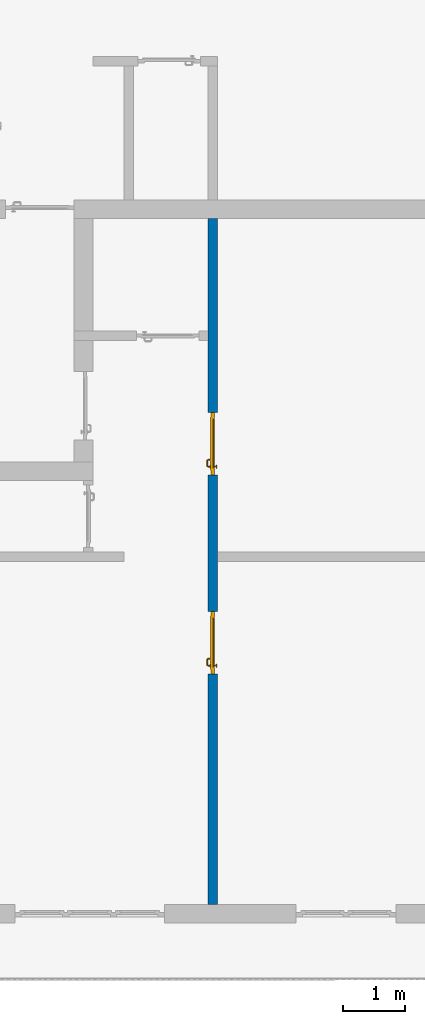
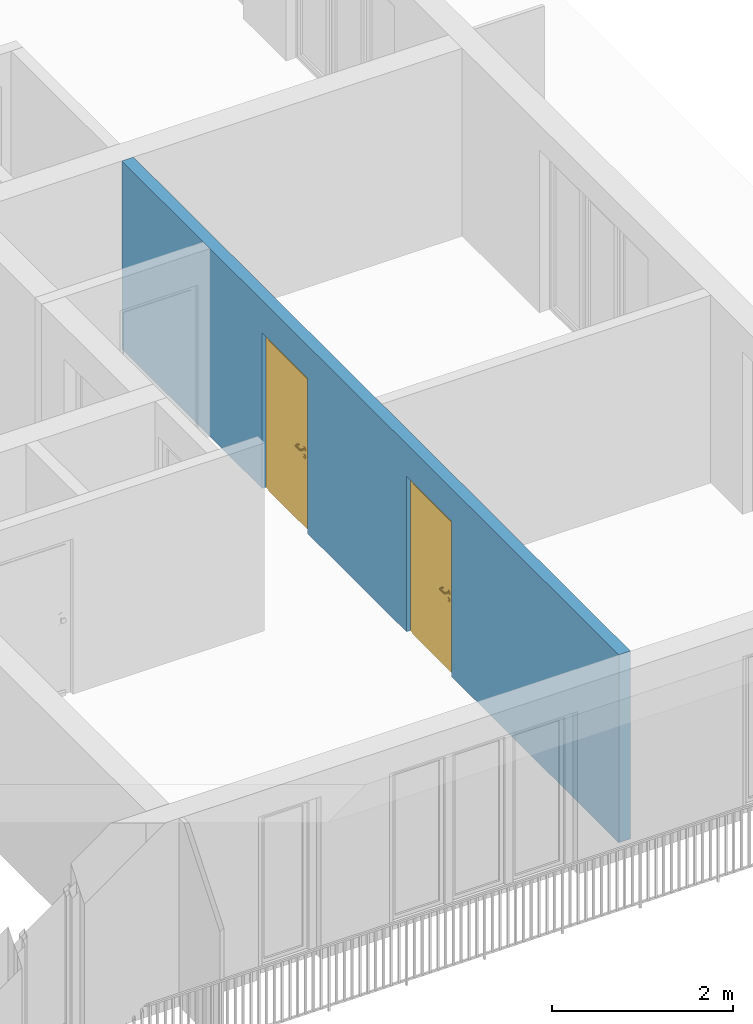
# One storey, part 20 of 54: 2 doors, 1 wall, 2 openings.
"""IFC4 building model written with IfcOpenShell, lengths in metres."""

from ifc_helpers import new_model, entity, si_unit, converted_unit, derived_unit, direction, frame, origin_with_axes, place, context, subcontext, project, spatial, polygons, source, transform, mapped, material, type_object, element, fill, save


model = new_model("IFC4")

# Units and contexts
model_context = context("Model", 3, precision=1e-05, world=origin_with_axes(), true_north=direction((0.0, 1.0)))
body_context = subcontext(model_context, "Body", "Model", "MODEL_VIEW")
ifc_project = project(units=[si_unit("LENGTHUNIT", "METRE"), si_unit("AREAUNIT", "SQUARE_METRE"), si_unit("VOLUMEUNIT", "CUBIC_METRE"), converted_unit("PLANEANGLEUNIT", "DEGREE", entity("IfcPlaneAngleMeasure", 0.0174532925199), si_unit("PLANEANGLEUNIT", "RADIAN"), dimensions=[0, 0, 0, 0, 0, 0, 0]), converted_unit("TIMEUNIT", "Year", entity("IfcTimeMeasure", 31556926.0), si_unit("TIMEUNIT", "SECOND"), dimensions=[0, 0, 1, 0, 0, 0, 0]), si_unit("MASSUNIT", "GRAM", prefix="KILO"), si_unit("THERMODYNAMICTEMPERATUREUNIT", "DEGREE_CELSIUS"), si_unit("LUMINOUSINTENSITYUNIT", "LUMEN"), si_unit("ENERGYUNIT", "JOULE", prefix="MEGA"), derived_unit("THERMALCONDUCTANCEUNIT", [(si_unit("POWERUNIT", "WATT"), 1), (si_unit("LENGTHUNIT", "METRE"), -1), (si_unit("THERMODYNAMICTEMPERATUREUNIT", "KELVIN"), -1)]), derived_unit("SPECIFICHEATCAPACITYUNIT", [(si_unit("ENERGYUNIT", "JOULE"), 1), (si_unit("MASSUNIT", "GRAM", prefix="KILO"), -1), (si_unit("THERMODYNAMICTEMPERATUREUNIT", "KELVIN"), -1)]), derived_unit("MASSDENSITYUNIT", [(si_unit("MASSUNIT", "GRAM", prefix="KILO"), 1), (si_unit("VOLUMEUNIT", "CUBIC_METRE"), -1)])], contexts=[model_context])

# Site, building, storey
site_placement = place(None, origin_with_axes())
site = spatial("IfcSite", under=ifc_project, at=site_placement, CompositionType="ELEMENT")
building_placement = place(site_placement, origin_with_axes())
building = spatial("IfcBuilding", under=site, at=building_placement, CompositionType="ELEMENT")
storey_placement = place(building_placement, frame((0.0, 0.0, 9.18), z_axis=(0.0, 0.0, 1.0), x_axis=(1.0, 0.0, 0.0)))
storey = spatial("IfcBuildingStorey", under=building, at=storey_placement, Name="3. Geschoss", CompositionType="ELEMENT", Elevation=9.18)

# Wall, openings, doors
ifc_material = material()
wall_type = type_object("IfcWallType", Name="150", PredefinedType="NOTDEFINED")
wall_placement = place(storey_placement, frame((4.6878006196, -9.92881223104, 0.0), z_axis=(0.0, 0.0, 1.0), x_axis=(0.0, 1.0, 0.0)))
wall = element("IfcWall", 1, at=wall_placement, inside=storey, type_object=wall_type, material=ifc_material, Name="Wand-002", PredefinedType="NOTDEFINED", context=body_context, shape_type="Tessellation", body=[
    polygons([(4.0, -0.15, 2.1), (4.0, 0.0, 2.1), (5.0, 0.0, 2.1), (5.0, -0.15, 2.1), (4.0, -0.1, 0.0), (4.0, 0.0, 0.0), (4.0, -0.15, 0.0), (0.3, 0.0, 0.0), (0.3, 0.0, 2.54), (11.3, 0.0, 2.54), (11.3, 0.0, 0.0), (8.1921181063, 0.0, 0.0), (8.1921181063, 0.0, 2.1), (7.1921181063, 0.0, 2.1), (7.1921181063, 0.0, 0.0), (5.0, 0.0, 0.0), (5.0, -0.1, 0.0), (5.0, -0.15, 0.0), (11.3, -0.15, 2.54), (0.3, -0.15, 2.54), (0.3, -0.15, 0.0), (7.1921181063, -0.15, 0.0), (7.1921181063, -0.15, 2.1), (8.1921181063, -0.15, 2.1), (8.1921181063, -0.15, 0.0), (11.3, -0.15, 0.0)], [[[1, 2, 3, 4]], [[5, 6, 2, 1, 7]], [[2, 6, 8, 9, 10, 11, 12, 13, 14, 15, 16, 3]], [[4, 3, 16, 17, 18]], [[19, 20, 21, 7, 1, 4, 18, 22, 23, 24, 25, 26]], [[6, 5, 7, 21, 8]], [[21, 20, 9, 8]], [[9, 20, 19, 10]], [[11, 10, 19, 26]], [[26, 25, 12, 11]], [[25, 24, 13, 12]], [[13, 24, 23, 14]], [[23, 22, 15, 14]], [[17, 16, 15, 22, 18]]], closed=True),
])
opening_1_placement = place(wall_placement, frame((7.6921181063, 0.0, 0.0), z_axis=(0.0, 0.0, 1.0), x_axis=(1.0, 0.0, 0.0)))
opening_1 = element("IfcOpeningElement", 2, at=opening_1_placement, cuts=wall, context=body_context, identifier="Reference", shape_type="Tessellation", body=[
    polygons([(0.5, -0.1, 0.0), (0.5, -0.1, 2.1), (0.5, -0.151, 2.1), (0.5, -0.151, 0.0), (0.5, 0.001, 0.0), (0.5, 0.001, 2.1), (-0.5, -0.1, 2.1), (-0.5, -0.151, 2.1), (-0.5, 0.001, 2.1), (-0.5, -0.151, 0.0), (-0.5, -0.1, 0.0), (-0.5, 0.001, 0.0)], [[[1, 2, 3, 4]], [[2, 1, 5, 6]], [[7, 8, 3, 2, 6, 9]], [[8, 10, 4, 3]], [[1, 4, 10, 11, 12, 5]], [[6, 5, 12, 9]], [[7, 11, 10, 8]], [[11, 7, 9, 12]]], closed=True),
])
opening_2_placement = place(wall_placement, frame((4.5, 0.0, 0.0), z_axis=(0.0, 0.0, 1.0), x_axis=(1.0, 0.0, 0.0)))
opening_2 = element("IfcOpeningElement", 3, at=opening_2_placement, cuts=wall, context=body_context, identifier="Reference", shape_type="Tessellation", body=[
    polygons([(0.5, -0.1, 0.0), (0.5, -0.1, 2.1), (0.5, -0.151, 2.1), (0.5, -0.151, 0.0), (0.5, 0.001, 0.0), (0.5, 0.001, 2.1), (-0.5, -0.1, 2.1), (-0.5, -0.151, 2.1), (-0.5, 0.001, 2.1), (-0.5, -0.151, 0.0), (-0.5, -0.1, 0.0), (-0.5, 0.001, 0.0)], [[[1, 2, 3, 4]], [[2, 1, 5, 6]], [[7, 8, 3, 2, 6, 9]], [[8, 10, 4, 3]], [[1, 4, 10, 11, 12, 5]], [[6, 5, 12, 9]], [[7, 11, 10, 8]], [[11, 7, 9, 12]]], closed=True),
])
door_type = type_object("IfcDoorType", Name="Eingang 01 1-Fl 26", OperationType="SINGLE_SWING_RIGHT", PredefinedType="DOOR")
shared_shape = source(origin_with_axes(), body_context, "Body", "Tessellation", [
    polygons([(0.5, -0.05, 0.0), (0.5, -0.03, 0.0), (0.5, -0.03, 2.1), (0.5, -0.05, 2.1), (0.4, -0.05, 0.0), (0.4, -0.03, 0.0), (0.4, -0.03, 2.0), (0.1301, -0.03, 2.0), (0.0001, -0.03, 2.0), (-0.4, -0.03, 2.0), (-0.4, -0.03, 0.0), (-0.5, -0.03, 0.0), (-0.5, -0.03, 2.1), (-0.5, -0.05, 2.1), (-0.5, -0.05, 0.0), (-0.4, -0.05, 0.0), (-0.4, -0.05, 2.0), (0.0001, -0.05, 2.0), (0.1301, -0.05, 2.0), (0.4, -0.05, 2.0)], [[[1, 2, 3, 4]], [[5, 6, 2, 1]], [[2, 6, 7, 8, 9, 10, 11, 12, 13, 3]], [[4, 3, 13, 14]], [[1, 4, 14, 15, 16, 17, 18, 19, 20, 5]], [[20, 7, 6, 5]], [[19, 8, 7, 20]], [[18, 9, 8, 19]], [[17, 10, 9, 18]], [[16, 11, 10, 17]], [[15, 12, 11, 16]], [[14, 13, 12, 15]]], closed=True),
    polygons([(0.5, -0.03, 0.0), (0.5, 0.0, 0.0), (0.5, 0.0, 2.1), (0.5, -0.03, 2.1), (0.43, -0.03, 0.0), (0.43, 0.0, 0.0), (0.43, 0.0, 2.03), (0.1001, 0.0, 2.03), (0.0301, 0.0, 2.03), (-0.43, 0.0, 2.03), (-0.43, 0.0, 0.0), (-0.5, 0.0, 0.0), (-0.5, 0.0, 2.1), (-0.5, -0.03, 2.1), (-0.5, -0.03, 0.0), (-0.43, -0.03, 0.0), (-0.43, -0.03, 2.03), (0.0301, -0.03, 2.03), (0.1001, -0.03, 2.03), (0.43, -0.03, 2.03)], [[[1, 2, 3, 4]], [[5, 6, 2, 1]], [[2, 6, 7, 8, 9, 10, 11, 12, 13, 3]], [[4, 3, 13, 14]], [[1, 4, 14, 15, 16, 17, 18, 19, 20, 5]], [[20, 7, 6, 5]], [[19, 8, 7, 20]], [[18, 9, 8, 19]], [[17, 10, 9, 18]], [[16, 11, 10, 17]], [[15, 12, 11, 16]], [[14, 13, 12, 15]]], closed=True),
    polygons([(0.43, 0.01, 0.0), (-0.43, 0.01, 0.0), (-0.43, 0.01, 2.03), (0.43, 0.01, 2.03), (0.43, -0.03, 0.0), (-0.43, -0.03, 0.0), (-0.43, -0.03, 2.03), (0.43, -0.03, 2.03)], [[[1, 2, 3, 4]], [[2, 1, 5, 6]], [[3, 2, 6, 7]], [[4, 3, 7, 8]], [[1, 4, 8, 5]], [[6, 5, 8, 7]]], closed=True),
    polygons([(0.395, -0.05, 0.0), (0.395, -0.05, 0.05), (-0.395, -0.05, 0.05), (-0.395, -0.05, 0.0), (0.395, -0.03, 0.0), (0.395, -0.03, 0.07), (0.395, -0.035, 0.07), (-0.395, -0.035, 0.07), (-0.395, -0.03, 0.07), (-0.395, -0.03, 0.0)], [[[1, 2, 3, 4]], [[1, 5, 6, 7, 2]], [[2, 7, 8, 3]], [[4, 3, 8, 9, 10]], [[5, 1, 4, 10]], [[6, 5, 10, 9]], [[7, 6, 9, 8]]], closed=True),
    polygons([(-0.3835, 0.02, 1.0733826859), (-0.3835, 0.0199, 1.0733826859), (-0.37, 0.0199, 1.077), (-0.37, 0.02, 1.077), (-0.393382685902, 0.02, 1.0635), (-0.393382685902, 0.0199, 1.0635), (-0.3835, 0.0101, 1.0733826859), (-0.37, 0.0101, 1.077), (-0.3565, 0.0199, 1.0733826859), (-0.3565, 0.02, 1.0733826859), (-0.346617314098, 0.02, 1.0635), (-0.343, 0.02, 1.05), (-0.346617314098, 0.02, 1.0365), (-0.3565, 0.02, 1.0266173141), (-0.37, 0.02, 1.023), (-0.3835, 0.02, 1.0266173141), (-0.393382685902, 0.02, 1.0365), (-0.397, 0.02, 1.05), (-0.397, 0.0199, 1.05), (-0.393382685902, 0.0101, 1.0635), (-0.3835, 0.01, 1.0733826859), (-0.37, 0.01, 1.077), (-0.3565, 0.0101, 1.0733826859), (-0.346617314098, 0.0199, 1.0635), (-0.343, 0.0199, 1.05), (-0.346617314098, 0.0199, 1.0365), (-0.3565, 0.0199, 1.0266173141), (-0.37, 0.0199, 1.023), (-0.3835, 0.0199, 1.0266173141), (-0.393382685902, 0.0199, 1.0365), (-0.397, 0.0101, 1.05), (-0.393382685902, 0.01, 1.0635), (-0.397, 0.01, 1.05), (-0.393382685902, 0.01, 1.0365), (-0.3835, 0.01, 1.0266173141), (-0.37, 0.01, 1.023), (-0.3565, 0.01, 1.0266173141), (-0.346617314098, 0.01, 1.0365), (-0.343, 0.01, 1.05), (-0.346617314098, 0.01, 1.0635), (-0.3565, 0.01, 1.0733826859), (-0.346617314098, 0.0101, 1.0635), (-0.343, 0.0101, 1.05), (-0.346617314098, 0.0101, 1.0365), (-0.3565, 0.0101, 1.0266173141), (-0.37, 0.0101, 1.023), (-0.3835, 0.0101, 1.0266173141), (-0.393382685902, 0.0101, 1.0365)], [[[1, 2, 3, 4]], [[5, 6, 2, 1]], [[2, 7, 8, 3]], [[4, 3, 9, 10]], [[4, 10, 11, 12, 13, 14, 15, 16, 17, 18, 5, 1]], [[18, 19, 6, 5]], [[6, 20, 7, 2]], [[7, 21, 22, 8]], [[3, 8, 23, 9]], [[10, 9, 24, 11]], [[11, 24, 25, 12]], [[12, 25, 26, 13]], [[13, 26, 27, 14]], [[14, 27, 28, 15]], [[15, 28, 29, 16]], [[16, 29, 30, 17]], [[17, 30, 19, 18]], [[19, 31, 20, 6]], [[20, 32, 21, 7]], [[22, 21, 32, 33, 34, 35, 36, 37, 38, 39, 40, 41]], [[8, 22, 41, 23]], [[9, 23, 42, 24]], [[24, 42, 43, 25]], [[25, 43, 44, 26]], [[26, 44, 45, 27]], [[27, 45, 46, 28]], [[28, 46, 47, 29]], [[29, 47, 48, 30]], [[30, 48, 31, 19]], [[31, 33, 32, 20]], [[48, 34, 33, 31]], [[47, 35, 34, 48]], [[46, 36, 35, 47]], [[45, 37, 36, 46]], [[44, 38, 37, 45]], [[43, 39, 38, 44]], [[42, 40, 39, 43]], [[23, 41, 40, 42]]], closed=True),
    polygons([(-0.362532169224, 0.019, 0.959692280177), (-0.365, 0.019, 0.9544), (-0.365, 0.019, 0.952886751346), (-0.347569942042, 0.019, 0.96295), (-0.35705, 0.019, 0.972430057958), (-0.363279754556, 0.019, 0.961639806549), (-0.362532169224, 0.02, 0.959692280177), (-0.365, 0.02, 0.9544), (-0.365, 0.02, 0.952886751346), (-0.365, 0.02, 0.95), (-0.365, 0.02, 0.947113248654), (-0.365, 0.02, 0.941339745962), (-0.365, 0.02, 0.9375), (-0.365, 0.019, 0.9375), (-0.365, 0.019, 0.941339745962), (-0.365, 0.019, 0.947113248654), (-0.365, 0.019, 0.95), (-0.3441, 0.019, 0.95), (-0.347483339502, 0.019, 0.963), (-0.357, 0.019, 0.972516660498), (-0.364624817685, 0.019, 0.965143815798), (-0.37, 0.019, 0.9759), (-0.37, 0.019, 0.967425445323), (-0.364624817685, 0.02, 0.965143815798), (-0.363279754556, 0.02, 0.961639806549), (-0.35655, 0.02, 0.973296083362), (-0.346703916638, 0.02, 0.96345), (-0.3431, 0.02, 0.95), (-0.346703916638, 0.02, 0.93655), (-0.35655, 0.02, 0.926703916638), (-0.37, 0.02, 0.9231), (-0.37, 0.02, 0.9325), (-0.366464466094, 0.02, 0.933964466094), (-0.366464466094, 0.019, 0.933964466094), (-0.35705, 0.019, 0.927569942042), (-0.37, 0.019, 0.9325), (-0.37, 0.019, 0.9241), (-0.347569942042, 0.019, 0.93705), (-0.344, 0.019, 0.95), (-0.347483339502, 0.0189, 0.963), (-0.357, 0.0189, 0.972516660498), (-0.37, 0.019, 0.976), (-0.375375182315, 0.019, 0.965143815798), (-0.38295, 0.019, 0.972430057958), (-0.376720245444, 0.019, 0.961639806549), (-0.37, 0.02, 0.967425445323), (-0.37, 0.02, 0.9769), (-0.346617314098, 0.02, 0.9635), (-0.3565, 0.02, 0.973382685902), (-0.343, 0.02, 0.95), (-0.346617314098, 0.02, 0.9365), (-0.3565, 0.02, 0.926617314098), (-0.38345, 0.02, 0.926703916638), (-0.375, 0.02, 0.941339745962), (-0.375, 0.02, 0.9375), (-0.373535533906, 0.02, 0.933964466094), (-0.37, 0.02, 0.923), (-0.373535533906, 0.019, 0.933964466094), (-0.375, 0.019, 0.9375), (-0.375, 0.019, 0.941339745962), (-0.38295, 0.019, 0.927569942042), (-0.37, 0.019, 0.924), (-0.357, 0.019, 0.927483339502), (-0.347483339502, 0.019, 0.937), (-0.344, 0.0189, 0.95), (-0.347483339502, 0.0101, 0.963), (-0.357, 0.0101, 0.972516660498), (-0.37, 0.0189, 0.976), (-0.383, 0.019, 0.972516660498), (-0.375375182315, 0.02, 0.965143815798), (-0.377467830776, 0.019, 0.959692280177), (-0.392430057958, 0.019, 0.96295), (-0.375, 0.019, 0.952886751346), (-0.375, 0.019, 0.9544), (-0.377467830776, 0.02, 0.959692280177), (-0.376720245444, 0.02, 0.961639806549), (-0.38345, 0.02, 0.973296083362), (-0.37, 0.02, 0.977), (-0.346617314098, 0.0199, 0.9635), (-0.3565, 0.0199, 0.973382685902), (-0.343, 0.0199, 0.95), (-0.346617314098, 0.0199, 0.9365), (-0.3565, 0.0199, 0.926617314098), (-0.393296083362, 0.02, 0.93655), (-0.375, 0.02, 0.947113248654), (-0.375, 0.02, 0.9544), (-0.375, 0.019, 0.95), (-0.375, 0.019, 0.947113248654), (-0.375, 0.02, 0.95), (-0.375, 0.02, 0.952886751346), (-0.3835, 0.02, 0.926617314098), (-0.37, 0.0199, 0.923), (-0.392430057958, 0.019, 0.93705), (-0.383, 0.019, 0.927483339502), (-0.37, 0.0189, 0.924), (-0.357, 0.0189, 0.927483339502), (-0.347483339502, 0.0189, 0.937), (-0.344, 0.0101, 0.95), (-0.347483339502, 0.01, 0.963), (-0.357, 0.01, 0.972516660498), (-0.37, 0.0101, 0.976), (-0.383, 0.0189, 0.972516660498), (-0.392516660498, 0.019, 0.963), (-0.3959, 0.019, 0.95), (-0.393296083362, 0.02, 0.96345), (-0.3835, 0.02, 0.973382685902), (-0.37, 0.0199, 0.977), (-0.346617314098, 0.0101, 0.9635), (-0.3565, 0.0101, 0.973382685902), (-0.343, 0.0101, 0.95), (-0.346617314098, 0.0101, 0.9365), (-0.3565, 0.0101, 0.926617314098), (-0.393382685902, 0.02, 0.9365), (-0.3969, 0.02, 0.95), (-0.3835, 0.0199, 0.926617314098), (-0.37, 0.0101, 0.923), (-0.392516660498, 0.019, 0.937), (-0.383, 0.0189, 0.927483339502), (-0.37, 0.0101, 0.924), (-0.357, 0.0101, 0.927483339502), (-0.347483339502, 0.0101, 0.937), (-0.344, 0.01, 0.95), (-0.347396736961, 0.01, 0.96305), (-0.35695, 0.01, 0.972603263039), (-0.37, 0.01, 0.976), (-0.383, 0.0101, 0.972516660498), (-0.392516660498, 0.0189, 0.963), (-0.396, 0.019, 0.95), (-0.393382685902, 0.02, 0.9635), (-0.3835, 0.0199, 0.973382685902), (-0.37, 0.0101, 0.977), (-0.346617314098, 0.01, 0.9635), (-0.3565, 0.01, 0.973382685902), (-0.343, 0.01, 0.95), (-0.346617314098, 0.01, 0.9365), (-0.3565, 0.01, 0.926617314098), (-0.397, 0.02, 0.95), (-0.393382685902, 0.0199, 0.9365), (-0.3835, 0.0101, 0.926617314098), (-0.37, 0.01, 0.923), (-0.392516660498, 0.0189, 0.937), (-0.383, 0.0101, 0.927483339502), (-0.37, 0.01, 0.924), (-0.357, 0.01, 0.927483339502), (-0.347483339502, 0.01, 0.937), (-0.3439, 0.01, 0.95), (-0.346703916638, 0.01, 0.96345), (-0.35655, 0.01, 0.973296083362), (-0.37, 0.01, 0.9761), (-0.383, 0.01, 0.972516660498), (-0.392516660498, 0.0101, 0.963), (-0.396, 0.0189, 0.95), (-0.393382685902, 0.0199, 0.9635), (-0.3835, 0.0101, 0.973382685902), (-0.37, 0.01, 0.977), (-0.3431, 0.01, 0.95), (-0.346703916638, 0.01, 0.93655), (-0.35655, 0.01, 0.926703916638), (-0.397, 0.0199, 0.95), (-0.393382685902, 0.0101, 0.9365), (-0.3835, 0.01, 0.926617314098), (-0.37, 0.01, 0.9231), (-0.392516660498, 0.0101, 0.937), (-0.383, 0.01, 0.927483339502), (-0.37, 0.01, 0.9239), (-0.35695, 0.01, 0.927396736961), (-0.347396736961, 0.01, 0.93695), (-0.37, 0.01, 0.9769), (-0.38305, 0.01, 0.972603263039), (-0.392516660498, 0.01, 0.963), (-0.396, 0.0101, 0.95), (-0.393382685902, 0.0101, 0.9635), (-0.3835, 0.01, 0.973382685902), (-0.397, 0.0101, 0.95), (-0.393382685902, 0.01, 0.9365), (-0.38345, 0.01, 0.926703916638), (-0.392516660498, 0.01, 0.937), (-0.38305, 0.01, 0.927396736961), (-0.38345, 0.01, 0.973296083362), (-0.392603263039, 0.01, 0.96305), (-0.396, 0.01, 0.95), (-0.393382685902, 0.01, 0.9635), (-0.397, 0.01, 0.95), (-0.393296083362, 0.01, 0.93655), (-0.392603263039, 0.01, 0.93695), (-0.393296083362, 0.01, 0.96345), (-0.3961, 0.01, 0.95), (-0.3969, 0.01, 0.95)], [[[1, 2, 3, 4, 5, 6]], [[2, 1, 7, 8]], [[2, 8, 9, 10, 11, 12, 13, 14, 15, 16, 17, 3]], [[17, 18, 4, 3]], [[4, 19, 20, 5]], [[21, 6, 5, 22, 23]], [[1, 6, 21, 24, 25, 7]], [[7, 25, 26, 27, 9, 8]], [[9, 27, 28, 10]], [[10, 28, 29, 11]], [[11, 29, 30, 12]], [[31, 32, 33, 13, 12, 30]], [[14, 13, 33, 34]], [[35, 15, 14, 34, 36, 37]], [[15, 35, 38, 16]], [[16, 38, 18, 17]], [[18, 39, 19, 4]], [[19, 40, 41, 20]], [[5, 20, 42, 22]], [[43, 23, 22, 44, 45]], [[21, 23, 46, 24]], [[24, 46, 47, 26, 25]], [[48, 27, 26, 49]], [[50, 28, 27, 48]], [[51, 29, 28, 50]], [[52, 30, 29, 51]], [[53, 54, 55, 56, 32, 31]], [[34, 33, 32, 36]], [[57, 31, 30, 52]], [[37, 36, 58, 59, 60, 61]], [[37, 62, 63, 35]], [[35, 63, 64, 38]], [[38, 64, 39, 18]], [[39, 65, 40, 19]], [[40, 66, 67, 41]], [[20, 41, 68, 42]], [[22, 42, 69, 44]], [[23, 43, 70, 46]], [[71, 45, 44, 72, 73, 74]], [[43, 45, 71, 75, 76, 70]], [[70, 76, 77, 47, 46]], [[49, 26, 47, 78]], [[79, 48, 49, 80]], [[81, 50, 48, 79]], [[82, 51, 50, 81]], [[83, 52, 51, 82]], [[54, 53, 84, 85]], [[86, 74, 73, 87, 88, 60, 59, 55, 54, 85, 89, 90]], [[58, 56, 55, 59]], [[36, 32, 56, 58]], [[91, 53, 31, 57]], [[92, 57, 52, 83]], [[88, 93, 61, 60]], [[61, 94, 62, 37]], [[62, 95, 96, 63]], [[63, 96, 97, 64]], [[64, 97, 65, 39]], [[65, 98, 66, 40]], [[66, 99, 100, 67]], [[41, 67, 101, 68]], [[42, 68, 102, 69]], [[44, 69, 103, 72]], [[73, 72, 104, 87]], [[71, 74, 86, 75]], [[75, 86, 90, 105, 77, 76]], [[78, 47, 77, 106]], [[80, 49, 78, 107]], [[108, 79, 80, 109]], [[110, 81, 79, 108]], [[111, 82, 81, 110]], [[112, 83, 82, 111]], [[113, 84, 53, 91]], [[85, 84, 114, 89]], [[87, 104, 93, 88]], [[89, 114, 105, 90]], [[115, 91, 57, 92]], [[116, 92, 83, 112]], [[93, 117, 94, 61]], [[94, 118, 95, 62]], [[95, 119, 120, 96]], [[96, 120, 121, 97]], [[97, 121, 98, 65]], [[98, 122, 99, 66]], [[99, 123, 124, 100]], [[67, 100, 125, 101]], [[68, 101, 126, 102]], [[69, 102, 127, 103]], [[72, 103, 128, 104]], [[106, 77, 105, 129]], [[107, 78, 106, 130]], [[109, 80, 107, 131]], [[132, 108, 109, 133]], [[134, 110, 108, 132]], [[135, 111, 110, 134]], [[136, 112, 111, 135]], [[137, 114, 84, 113]], [[138, 113, 91, 115]], [[104, 128, 117, 93]], [[129, 105, 114, 137]], [[139, 115, 92, 116]], [[140, 116, 112, 136]], [[117, 141, 118, 94]], [[118, 142, 119, 95]], [[119, 143, 144, 120]], [[120, 144, 145, 121]], [[121, 145, 122, 98]], [[122, 146, 123, 99]], [[123, 147, 148, 124]], [[100, 124, 149, 125]], [[101, 125, 150, 126]], [[102, 126, 151, 127]], [[103, 127, 152, 128]], [[130, 106, 129, 153]], [[131, 107, 130, 154]], [[133, 109, 131, 155]], [[147, 132, 133, 148]], [[156, 134, 132, 147]], [[157, 135, 134, 156]], [[158, 136, 135, 157]], [[159, 137, 113, 138]], [[160, 138, 115, 139]], [[128, 152, 141, 117]], [[153, 129, 137, 159]], [[161, 139, 116, 140]], [[162, 140, 136, 158]], [[141, 163, 142, 118]], [[142, 164, 143, 119]], [[143, 165, 166, 144]], [[144, 166, 167, 145]], [[145, 167, 146, 122]], [[146, 156, 147, 123]], [[124, 148, 168, 149]], [[125, 149, 169, 150]], [[126, 150, 170, 151]], [[127, 151, 171, 152]], [[154, 130, 153, 172]], [[155, 131, 154, 173]], [[148, 133, 155, 168]], [[167, 157, 156, 146]], [[166, 158, 157, 167]], [[174, 159, 138, 160]], [[175, 160, 139, 161]], [[152, 171, 163, 141]], [[172, 153, 159, 174]], [[176, 161, 140, 162]], [[165, 162, 158, 166]], [[163, 177, 164, 142]], [[164, 178, 165, 143]], [[149, 168, 179, 169]], [[150, 169, 180, 170]], [[151, 170, 181, 171]], [[173, 154, 172, 182]], [[168, 155, 173, 179]], [[183, 174, 160, 175]], [[184, 175, 161, 176]], [[171, 181, 177, 163]], [[182, 172, 174, 183]], [[178, 176, 162, 165]], [[177, 185, 178, 164]], [[169, 179, 186, 180]], [[170, 180, 187, 181]], [[179, 173, 182, 186]], [[188, 183, 175, 184]], [[185, 184, 176, 178]], [[181, 187, 185, 177]], [[186, 182, 183, 188]], [[180, 186, 188, 187]], [[187, 188, 184, 185]]], closed=True),
    polygons([(-0.38, 0.02, 1.05), (-0.38, 0.0509849140336, 1.05), (-0.377071067812, 0.050696439392, 1.04292893219), (-0.377071067812, 0.02, 1.04292893219), (-0.377071067812, 0.02, 1.05707106781), (-0.377071067812, 0.050696439392, 1.05707106781), (-0.378277987014, 0.0596420579258, 1.05), (-0.375518993221, 0.0584992452783, 1.04292893219), (-0.37, 0.05, 1.04), (-0.37, 0.02, 1.04), (-0.37, 0.02, 1.06), (-0.37, 0.05, 1.06), (-0.375518993221, 0.0584992452783, 1.05707106781), (-0.372816199938, 0.0678161999379, 1.05), (-0.370704557509, 0.0657045575088, 1.04292893219), (-0.368858192988, 0.0557402514855, 1.04), (-0.362928932188, 0.049303560608, 1.04292893219), (-0.362928932188, 0.02, 1.04292893219), (-0.362928932188, 0.02, 1.05707106781), (-0.362928932188, 0.049303560608, 1.05707106781), (-0.368858192988, 0.0557402514855, 1.06), (-0.370704557509, 0.0657045575088, 1.05707106781), (-0.364642057926, 0.0732779870137, 1.05), (-0.363499245278, 0.0705189932208, 1.04292893219), (-0.365606601718, 0.0606066017178, 1.04), (-0.362197392755, 0.0529812576926, 1.04292893219), (-0.36, 0.0490150859664, 1.05), (-0.36, 0.02, 1.05), (-0.362197392755, 0.0529812576926, 1.05707106781), (-0.365606601718, 0.0606066017178, 1.06), (-0.363499245278, 0.0705189932208, 1.05707106781), (-0.355984914034, 0.075, 1.05), (-0.355696439392, 0.0720710678119, 1.04292893219), (-0.360740251485, 0.0638581929877, 1.04), (-0.360508645927, 0.0555086459268, 1.04292893219), (-0.359438398962, 0.0518384450452, 1.05), (-0.360508645927, 0.0555086459268, 1.05707106781), (-0.360740251485, 0.0638581929877, 1.06), (-0.355696439392, 0.0720710678119, 1.05707106781), (-0.274015085966, 0.075, 1.05), (-0.274303560608, 0.0720710678119, 1.04292893219), (-0.355, 0.065, 1.04), (-0.357981257693, 0.0571973927545, 1.04292893219), (-0.358397003498, 0.0533970034977, 1.05), (-0.357981257693, 0.0571973927545, 1.05707106781), (-0.355, 0.065, 1.06), (-0.274303560608, 0.0720710678119, 1.05707106781), (-0.265357942074, 0.0732779870137, 1.05), (-0.266500754722, 0.0705189932208, 1.04292893219), (-0.275, 0.065, 1.04), (-0.354303560608, 0.0579289321881, 1.04292893219), (-0.356838445045, 0.0544383989617, 1.05), (-0.354303560608, 0.0579289321881, 1.05707106781), (-0.275, 0.065, 1.06), (-0.266500754722, 0.0705189932208, 1.05707106781), (-0.257183800062, 0.0678161999379, 1.05), (-0.259295442491, 0.0657045575088, 1.04292893219), (-0.269259748515, 0.0638581929877, 1.04), (-0.275696439392, 0.0579289321881, 1.04292893219), (-0.354015085966, 0.055, 1.05), (-0.275696439392, 0.0579289321881, 1.05707106781), (-0.269259748515, 0.0638581929877, 1.06), (-0.259295442491, 0.0657045575088, 1.05707106781), (-0.251722012986, 0.0596420579258, 1.05), (-0.254481006779, 0.0584992452783, 1.04292893219), (-0.264393398282, 0.0606066017178, 1.04), (-0.272018742307, 0.0571973927545, 1.04292893219), (-0.275984914034, 0.055, 1.05), (-0.272018742307, 0.0571973927545, 1.05707106781), (-0.264393398282, 0.0606066017178, 1.06), (-0.254481006779, 0.0584992452783, 1.05707106781), (-0.25, 0.0509849140336, 1.05), (-0.252928932188, 0.050696439392, 1.04292893219), (-0.261141807012, 0.0557402514855, 1.04), (-0.269491354073, 0.0555086459268, 1.04292893219), (-0.273161554955, 0.0544383989617, 1.05), (-0.269491354073, 0.0555086459268, 1.05707106781), (-0.261141807012, 0.0557402514855, 1.06), (-0.252928932188, 0.050696439392, 1.05707106781), (-0.25, 0.02, 1.05), (-0.252928932188, 0.02, 1.04292893219), (-0.26, 0.05, 1.04), (-0.267802607245, 0.0529812576926, 1.04292893219), (-0.271602996502, 0.0533970034977, 1.05), (-0.267802607245, 0.0529812576926, 1.05707106781), (-0.26, 0.05, 1.06), (-0.252928932188, 0.02, 1.05707106781), (-0.26, 0.02, 1.06), (-0.267071067812, 0.02, 1.05707106781), (-0.27, 0.02, 1.05), (-0.267071067812, 0.02, 1.04292893219), (-0.26, 0.02, 1.04), (-0.267071067812, 0.049303560608, 1.04292893219), (-0.270561601038, 0.0518384450452, 1.05), (-0.267071067812, 0.049303560608, 1.05707106781), (-0.27, 0.0490150859664, 1.05)], [[[1, 2, 3, 4]], [[5, 6, 2, 1]], [[2, 7, 8, 3]], [[4, 3, 9, 10]], [[11, 12, 6, 5]], [[6, 13, 7, 2]], [[7, 14, 15, 8]], [[3, 8, 16, 9]], [[10, 9, 17, 18]], [[19, 20, 12, 11]], [[12, 21, 13, 6]], [[13, 22, 14, 7]], [[14, 23, 24, 15]], [[8, 15, 25, 16]], [[9, 16, 26, 17]], [[18, 17, 27, 28]], [[28, 27, 20, 19]], [[20, 29, 21, 12]], [[21, 30, 22, 13]], [[22, 31, 23, 14]], [[23, 32, 33, 24]], [[15, 24, 34, 25]], [[16, 25, 35, 26]], [[17, 26, 36, 27]], [[27, 36, 29, 20]], [[29, 37, 30, 21]], [[30, 38, 31, 22]], [[31, 39, 32, 23]], [[32, 40, 41, 33]], [[24, 33, 42, 34]], [[25, 34, 43, 35]], [[26, 35, 44, 36]], [[36, 44, 37, 29]], [[37, 45, 38, 30]], [[38, 46, 39, 31]], [[39, 47, 40, 32]], [[40, 48, 49, 41]], [[33, 41, 50, 42]], [[34, 42, 51, 43]], [[35, 43, 52, 44]], [[44, 52, 45, 37]], [[45, 53, 46, 38]], [[46, 54, 47, 39]], [[47, 55, 48, 40]], [[48, 56, 57, 49]], [[41, 49, 58, 50]], [[42, 50, 59, 51]], [[43, 51, 60, 52]], [[52, 60, 53, 45]], [[53, 61, 54, 46]], [[54, 62, 55, 47]], [[55, 63, 56, 48]], [[56, 64, 65, 57]], [[49, 57, 66, 58]], [[50, 58, 67, 59]], [[51, 59, 68, 60]], [[60, 68, 61, 53]], [[61, 69, 62, 54]], [[62, 70, 63, 55]], [[63, 71, 64, 56]], [[64, 72, 73, 65]], [[57, 65, 74, 66]], [[58, 66, 75, 67]], [[59, 67, 76, 68]], [[68, 76, 69, 61]], [[69, 77, 70, 62]], [[70, 78, 71, 63]], [[71, 79, 72, 64]], [[72, 80, 81, 73]], [[65, 73, 82, 74]], [[66, 74, 83, 75]], [[67, 75, 84, 76]], [[76, 84, 77, 69]], [[77, 85, 78, 70]], [[78, 86, 79, 71]], [[79, 87, 80, 72]], [[80, 87, 88, 89, 90, 91, 92, 81]], [[73, 81, 92, 82]], [[74, 82, 93, 83]], [[75, 83, 94, 84]], [[84, 94, 85, 77]], [[85, 95, 86, 78]], [[86, 88, 87, 79]], [[95, 89, 88, 86]], [[96, 90, 89, 95]], [[93, 91, 90, 96]], [[82, 92, 91, 93]], [[83, 93, 96, 94]], [[94, 96, 95, 85]]], closed=False),
    polygons([(-0.364696699141, -0.035, 1.04469669914), (-0.37, -0.035, 1.0425), (-0.375303300859, -0.035, 1.04469669914), (-0.3775, -0.035, 1.05), (-0.375303300859, -0.035, 1.05530330086), (-0.37, -0.035, 1.0575), (-0.364696699141, -0.035, 1.05530330086), (-0.3625, -0.035, 1.05), (-0.364696699141, -0.075, 1.04469669914), (-0.37, -0.075, 1.0425), (-0.375303300859, -0.075, 1.04469669914), (-0.3775, -0.075, 1.05), (-0.375303300859, -0.075, 1.05530330086), (-0.37, -0.075, 1.0575), (-0.364696699141, -0.075, 1.05530330086), (-0.3625, -0.075, 1.05)], [[[1, 2, 3, 4, 5, 6, 7, 8]], [[2, 1, 9, 10]], [[3, 2, 10, 11]], [[4, 3, 11, 12]], [[5, 4, 12, 13]], [[6, 5, 13, 14]], [[7, 6, 14, 15]], [[8, 7, 15, 16]], [[1, 8, 16, 9]], [[9, 16, 15, 14, 13, 12, 11, 10]]], closed=True),
    polygons([(-0.395, -0.03, 0.975), (-0.393096988313, -0.03, 0.965432914191), (-0.393096988313, -0.035, 0.965432914191), (-0.395, -0.035, 0.975), (-0.395, -0.03, 1.1), (-0.393096988313, -0.03, 1.10956708581), (-0.38767766953, -0.03, 1.11767766953), (-0.379567085809, -0.03, 1.12309698831), (-0.37, -0.03, 1.125), (-0.360432914191, -0.03, 1.12309698831), (-0.35232233047, -0.03, 1.11767766953), (-0.346903011687, -0.03, 1.10956708581), (-0.345, -0.03, 1.1), (-0.345, -0.03, 0.975), (-0.346903011687, -0.03, 0.965432914191), (-0.35232233047, -0.03, 0.95732233047), (-0.360432914191, -0.03, 0.951903011687), (-0.37, -0.03, 0.95), (-0.379567085809, -0.03, 0.951903011687), (-0.38767766953, -0.03, 0.95732233047), (-0.38767766953, -0.035, 0.95732233047), (-0.379567085809, -0.035, 0.951903011687), (-0.37, -0.035, 0.95), (-0.360432914191, -0.035, 0.951903011687), (-0.35232233047, -0.035, 0.95732233047), (-0.346903011687, -0.035, 0.965432914191), (-0.345, -0.035, 0.975), (-0.345, -0.035, 1.1), (-0.346903011687, -0.035, 1.10956708581), (-0.35232233047, -0.035, 1.11767766953), (-0.360432914191, -0.035, 1.12309698831), (-0.37, -0.035, 1.125), (-0.379567085809, -0.035, 1.12309698831), (-0.38767766953, -0.035, 1.11767766953), (-0.393096988313, -0.035, 1.10956708581), (-0.395, -0.035, 1.1)], [[[1, 2, 3, 4]], [[1, 5, 6, 7, 8, 9, 10, 11, 12, 13, 14, 15, 16, 17, 18, 19, 20, 2]], [[2, 20, 21, 3]], [[4, 3, 21, 22, 23, 24, 25, 26, 27, 28, 29, 30, 31, 32, 33, 34, 35, 36]], [[5, 1, 4, 36]], [[6, 5, 36, 35]], [[7, 6, 35, 34]], [[8, 7, 34, 33]], [[9, 8, 33, 32]], [[10, 9, 32, 31]], [[11, 10, 31, 30]], [[12, 11, 30, 29]], [[13, 12, 29, 28]], [[14, 13, 28, 27]], [[15, 14, 27, 26]], [[16, 15, 26, 25]], [[17, 16, 25, 24]], [[18, 17, 24, 23]], [[19, 18, 23, 22]], [[20, 19, 22, 21]]], closed=True),
    polygons([(-0.39, -0.075, 1.08), (-0.395, -0.075, 1.07866025404), (-0.395, -0.09, 1.07866025404), (-0.39, -0.09, 1.08), (-0.35, -0.075, 1.08), (-0.345, -0.075, 1.07866025404), (-0.341339745962, -0.075, 1.075), (-0.34, -0.075, 1.07), (-0.34, -0.075, 1.03), (-0.341339745962, -0.075, 1.025), (-0.345, -0.075, 1.02133974596), (-0.35, -0.075, 1.02), (-0.39, -0.075, 1.02), (-0.395, -0.075, 1.02133974596), (-0.398660254038, -0.075, 1.025), (-0.4, -0.075, 1.03), (-0.4, -0.075, 1.07), (-0.398660254038, -0.075, 1.075), (-0.398660254038, -0.09, 1.075), (-0.4, -0.09, 1.07), (-0.4, -0.09, 1.03), (-0.398660254038, -0.09, 1.025), (-0.395, -0.09, 1.02133974596), (-0.39, -0.09, 1.02), (-0.35, -0.09, 1.02), (-0.345, -0.09, 1.02133974596), (-0.341339745962, -0.09, 1.025), (-0.34, -0.09, 1.03), (-0.34, -0.09, 1.07), (-0.341339745962, -0.09, 1.075), (-0.345, -0.09, 1.07866025404), (-0.35, -0.09, 1.08)], [[[1, 2, 3, 4]], [[1, 5, 6, 7, 8, 9, 10, 11, 12, 13, 14, 15, 16, 17, 18, 2]], [[2, 18, 19, 3]], [[4, 3, 19, 20, 21, 22, 23, 24, 25, 26, 27, 28, 29, 30, 31, 32]], [[5, 1, 4, 32]], [[6, 5, 32, 31]], [[7, 6, 31, 30]], [[8, 7, 30, 29]], [[9, 8, 29, 28]], [[10, 9, 28, 27]], [[11, 10, 27, 26]], [[12, 11, 26, 25]], [[13, 12, 25, 24]], [[14, 13, 24, 23]], [[15, 14, 23, 22]], [[16, 15, 22, 21]], [[17, 16, 21, 20]], [[18, 17, 20, 19]]], closed=True),
])
door_1_placement = place(opening_1_placement, frame((-0.4, 0.0, 0.0), z_axis=(0.0, 0.0, 1.0), x_axis=(1.0, 0.0, 0.0)))
door_1 = element("IfcDoor", 4, at=door_1_placement, inside=storey, type_object=door_type, OverallHeight=2.1, OverallWidth=1.0, PredefinedType="DOOR", context=body_context, shape_type="MappedRepresentation", body=[
    mapped(shared_shape, transform((0.4, -0.05, 0.0))),
])
fill(opening_1, door_1)
door_2_placement = place(opening_2_placement, frame((-0.4, 0.0, 0.0), z_axis=(0.0, 0.0, 1.0), x_axis=(1.0, 0.0, 0.0)))
door_2 = element("IfcDoor", 5, at=door_2_placement, inside=storey, type_object=door_type, OverallHeight=2.1, OverallWidth=1.0, PredefinedType="DOOR", context=body_context, shape_type="MappedRepresentation", body=[
    mapped(shared_shape, transform((0.4, -0.05, 0.0))),
])
fill(opening_2, door_2)

save(model, "model.ifc")
